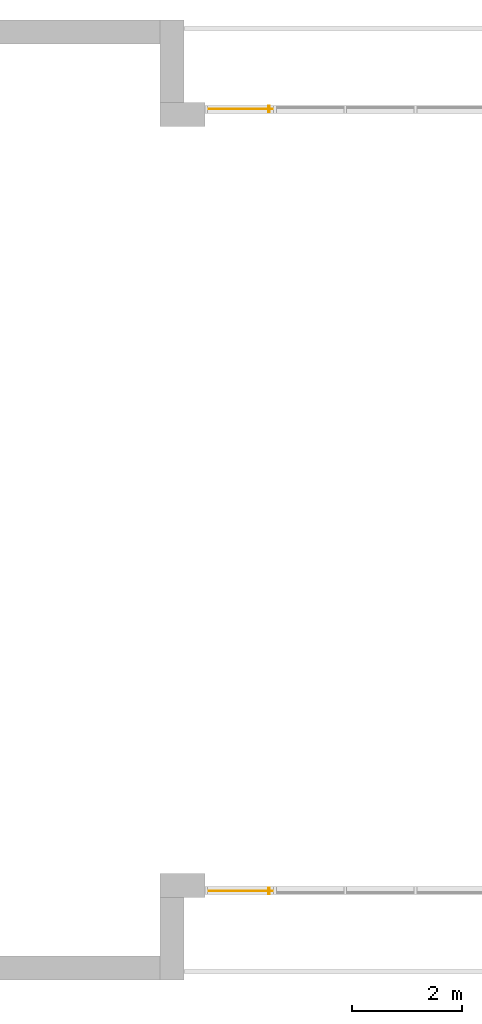
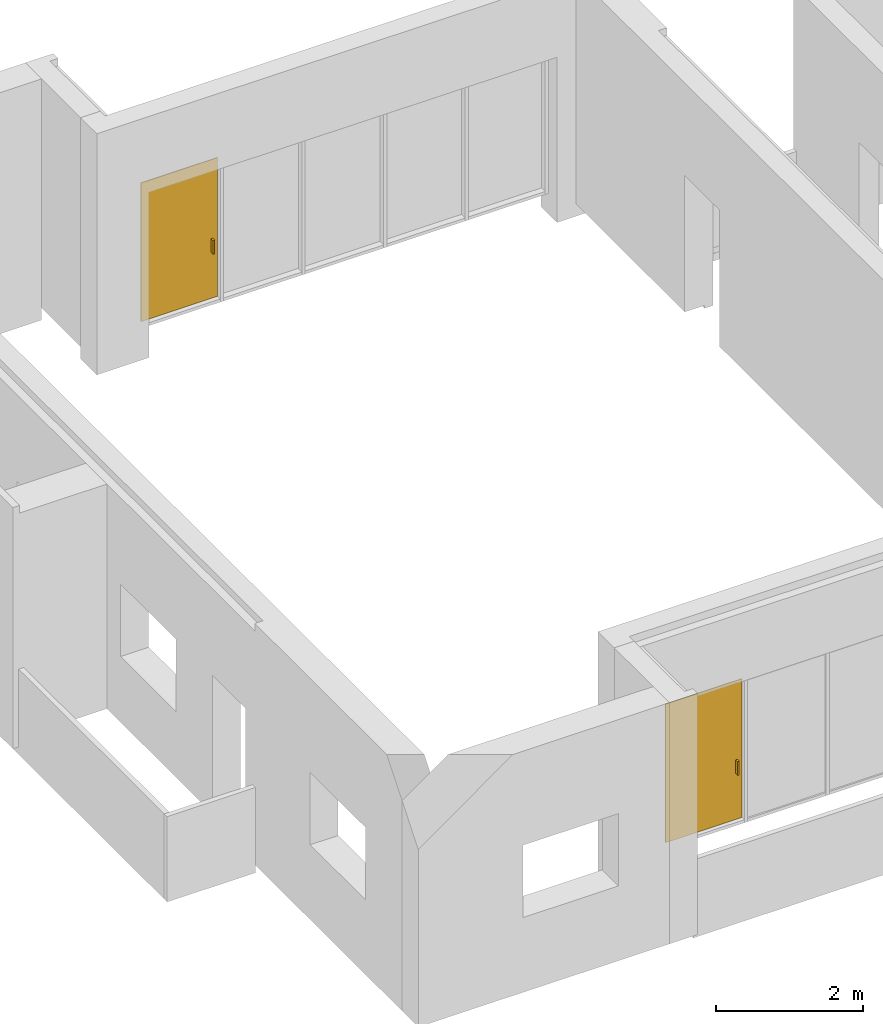
# One storey, part 4 of 4: 2 doors, 2 elements without a shape of their own.
"""IFC2X3 building model written with IfcOpenShell, lengths in millimetres."""

import ifcopenshell
import ifcopenshell.guid

model = None  # the IFC model being written
_history = None  # IfcOwnerHistory: only IFC2X3 demands one
_inside = {}  # id of a spatial element -> (the spatial element, [elements in it])
_under = {}  # id of a project, library or spatial element -> (it, [spatial elements below it])
_declared = {}  # id of a project -> (the project, [libraries it declares])
_typed = {}  # id of a type object -> (the type object, [elements of that type])
_made_of = {}  # id of a material, layer set ... -> (it, [elements and type objects made of it])


def new_model(schema):
    """Start an empty IFC model of exactly this schema.

    Asked for "IFC4X3", IfcOpenShell would pick the latest addendum, in which some entities
    have other attributes; the version numbers below select the first issue.
    IFC2X3 requires an IfcOwnerHistory on every rooted entity: one is made here for all.
    """
    global model, _history
    if schema == "IFC4X3":
        model = ifcopenshell.file(schema_version=(4, 3, 0, 0))
    else:
        model = ifcopenshell.file(schema=schema)
    _inside.clear()
    _under.clear()
    _declared.clear()
    _typed.clear()
    _made_of.clear()
    _history = None
    if model.schema == "IFC2X3":
        org = make("IfcOrganization", Name="unknown")
        user = make(
            "IfcPersonAndOrganization",
            ThePerson=make("IfcPerson", FamilyName="unknown"),
            TheOrganization=org,
        )
        app = make(
            "IfcApplication",
            ApplicationDeveloper=org,
            Version="unknown",
            ApplicationFullName="unknown",
            ApplicationIdentifier="unknown",
        )
        _history = make(
            "IfcOwnerHistory",
            OwningUser=user,
            OwningApplication=app,
            ChangeAction="ADDED",
            CreationDate=0,
        )
    return model


def make(cls, **values):
    """One entity of the class cls with the attributes given. An attribute that is None is left unset."""
    return model.create_entity(
        cls, **{name: value for name, value in values.items() if value is not None}
    )


def entity(cls, *values):
    """Any entity or typed value of the class cls, its attributes in the order of the schema. None: left unset."""
    e = model.create_entity(cls)
    for i, value in enumerate(values):
        if value is not None:
            e[i] = value
    return e


def rooted(cls, **values):
    """An entity with a GlobalId (a new one), such as an element, a storey or a relation."""
    return make(cls, GlobalId=ifcopenshell.guid.new(), OwnerHistory=_history, **values)


def si_unit(unit_type, name, prefix=None):
    """IfcSIUnit, for example si_unit("LENGTHUNIT", "METRE", prefix="MILLI")."""
    return make("IfcSIUnit", UnitType=unit_type, Prefix=prefix, Name=name)


def converted_unit(unit_type, name, factor, base, dimensions=None, offset=None):
    """IfcConversionBasedUnit, such as the inch: factor (a typed value) times the base unit."""
    return make(
        "IfcConversionBasedUnit"
        if offset is None
        else "IfcConversionBasedUnitWithOffset",
        ConversionOffset=offset,
        Dimensions=None
        if dimensions is None
        else entity("IfcDimensionalExponents", *dimensions),
        UnitType=unit_type,
        Name=name,
        ConversionFactor=make(
            "IfcMeasureWithUnit", ValueComponent=factor, UnitComponent=base
        ),
    )


def derived_unit(unit_type, elements):
    """IfcDerivedUnit: a product of units, each with its exponent."""
    return make(
        "IfcDerivedUnit",
        Elements=[
            make("IfcDerivedUnitElement", Unit=unit, Exponent=power)
            for unit, power in elements
        ],
        UnitType=unit_type,
    )


def assignment(units):
    """IfcUnitAssignment: the units of a project."""
    return None if units is None else make("IfcUnitAssignment", Units=units)


def point(xyz):
    """IfcCartesianPoint."""
    return None if xyz is None else make("IfcCartesianPoint", Coordinates=xyz)


def direction(xyz):
    """IfcDirection."""
    return None if xyz is None else make("IfcDirection", DirectionRatios=xyz)


def frame(location, z_axis=None, x_axis=None):
    """IfcAxis2Placement3D, a coordinate frame: its origin and axes. An axis left out is left unset."""
    return make(
        "IfcAxis2Placement3D",
        Location=point(location),
        Axis=direction(z_axis),
        RefDirection=direction(x_axis),
    )


def frame_2d(location, x_axis=None):
    """IfcAxis2Placement2D, a coordinate frame in the plane: its origin and x axis."""
    return make(
        "IfcAxis2Placement2D", Location=point(location), RefDirection=direction(x_axis)
    )


def origin():
    """The frame at (0, 0, 0) with its axes left unset."""
    return frame((0.0, 0.0, 0.0))


def origin_2d_with_axis():
    """The frame at (0, 0) in the plane with the x axis (1, 0) written out."""
    return frame_2d((0.0, 0.0), x_axis=(1.0, 0.0))


def place(relative_to, where):
    """IfcLocalPlacement: puts the frame where relative to a parent placement (None: the world)."""
    return make(
        "IfcLocalPlacement", PlacementRelTo=relative_to, RelativePlacement=where
    )


def context(
    kind, dimensions, precision=None, world=None, true_north=None, identifier=None
):
    """IfcGeometricRepresentationContext, for example the 3D "Model" context."""
    return make(
        "IfcGeometricRepresentationContext",
        ContextIdentifier=identifier,
        ContextType=kind,
        CoordinateSpaceDimension=dimensions,
        Precision=precision,
        WorldCoordinateSystem=world,
        TrueNorth=true_north,
    )


def subcontext(parent, identifier, kind, view, scale=None):
    """IfcGeometricRepresentationSubContext, for example "Body" below "Model"."""
    return make(
        "IfcGeometricRepresentationSubContext",
        ContextIdentifier=identifier,
        ContextType=kind,
        ParentContext=parent,
        TargetScale=scale,
        TargetView=view,
    )


def project(units=None, contexts=None):
    """IfcProject with its units and contexts."""
    return rooted(
        "IfcProject",
        Name="project",
        RepresentationContexts=contexts,
        UnitsInContext=assignment(units),
    )


def spatial(cls, under=None, at=None, **own):
    """A site, building, storey or space (cls), placed at a placement, below another one or the project."""
    s = rooted(cls, ObjectPlacement=at, **own)
    if under is not None:
        _under.setdefault(under.id(), (under, []))[1].append(s)
    return s


def profile(cls, at=None, kind="AREA", **sizes):
    """A parametric profile (cls). Its sizes go by their IFC names, for example OverallWidth=200.0."""
    return make(cls, ProfileType=kind, Position=at, **sizes)


def rectangle(**sizes):
    """IfcRectangleProfileDef."""
    return profile("IfcRectangleProfileDef", **sizes)


def extrude(swept, where, along, depth):
    """IfcExtrudedAreaSolid: the profile swept, set in the frame where, extruded along a direction by depth."""
    return make(
        "IfcExtrudedAreaSolid",
        SweptArea=swept,
        Position=where,
        ExtrudedDirection=direction(along),
        Depth=depth,
    )


def shape(context_of_items, identifier, shape_type, items):
    """IfcShapeRepresentation: the items that make up one representation, for example the "Body"."""
    return make(
        "IfcShapeRepresentation",
        ContextOfItems=context_of_items,
        RepresentationIdentifier=identifier,
        RepresentationType=shape_type,
        Items=items,
    )


def source(mapping_origin, context_of_items, identifier, shape_type, items):
    """IfcRepresentationMap: a shape defined once, which mapped items show again and again."""
    return make(
        "IfcRepresentationMap",
        MappingOrigin=mapping_origin,
        MappedRepresentation=shape(context_of_items, identifier, shape_type, items),
    )


def transform(
    local_origin,
    x_axis=None,
    y_axis=None,
    z_axis=None,
    scale=None,
    scale2=None,
    scale3=None,
    uniform=True,
):
    """IfcCartesianTransformationOperator3D, or its non-uniform kind. x_axis, y_axis, z_axis: its Axis1, 2, 3."""
    if uniform:
        return make(
            "IfcCartesianTransformationOperator3D",
            Axis1=direction(x_axis),
            Axis2=direction(y_axis),
            LocalOrigin=point(local_origin),
            Scale=scale,
            Axis3=direction(z_axis),
        )
    return make(
        "IfcCartesianTransformationOperator3DnonUniform",
        Axis1=direction(x_axis),
        Axis2=direction(y_axis),
        LocalOrigin=point(local_origin),
        Scale=scale,
        Axis3=direction(z_axis),
        Scale2=scale2,
        Scale3=scale3,
    )


def mapped(mapping_source, mapping_target):
    """IfcMappedItem: shows the shape of a source again, moved by a transform."""
    return make(
        "IfcMappedItem", MappingSource=mapping_source, MappingTarget=mapping_target
    )


def material(Name=None, Category=None):
    """IfcMaterial."""
    return make("IfcMaterial", Name=Name, Category=Category)


def material_list(materials):
    """IfcMaterialList."""
    return make("IfcMaterialList", Materials=materials)


def made_of(thing, what):
    """Note that an element or type object is made of a material, layer set ...; save() writes the relation."""
    if what is not None:
        _made_of.setdefault(what.id(), (what, []))[1].append(thing)
    return thing


def type_object(cls, material=None, **own):
    """A type object (cls), such as IfcWallType, which elements share."""
    return made_of(rooted(cls, **own), material)


def type_shapes(of_type, sources):
    """Give a type object the sources (RepresentationMaps) that its elements show as mapped items."""
    of_type.RepresentationMaps = sources


def element(
    cls,
    number,
    at=None,
    inside=None,
    cuts=None,
    type_object=None,
    material=None,
    context=None,
    identifier="Body",
    shape_type=None,
    held_by="IfcProductDefinitionShape",
    body=None,
    shapes=None,
    **own,
):
    """One element of the class cls, such as IfcWall. Its Tag is "e" and its number.

    at: its placement. inside: the storey or other place that contains it. cuts: it is an
    opening in that element (IfcRelVoidsElement). A single representation is given by context,
    identifier, shape_type and body (its items); several are given by shapes. held_by: the class
    of the entity that holds the representations. save() writes the other relations.
    """
    e = rooted(cls, Tag="e%d" % number, ObjectPlacement=at, **own)
    if body is not None:
        shapes = [shape(context, identifier, shape_type, body)]
    if shapes is not None:
        e.Representation = make(held_by, Representations=shapes)
    if inside is not None:
        _inside.setdefault(inside.id(), (inside, []))[1].append(e)
    if cuts is not None:
        rooted(
            "IfcRelVoidsElement", RelatingBuildingElement=cuts, RelatedOpeningElement=e
        )
    if type_object is not None:
        _typed.setdefault(type_object.id(), (type_object, []))[1].append(e)
    return made_of(e, material)


def aggregate(whole, parts):
    """IfcRelAggregates: a whole, such as a stair, and the parts it consists of."""
    return rooted("IfcRelAggregates", RelatingObject=whole, RelatedObjects=parts)


def save(model, path):
    """Write the relations noted so far, then the file.

    IfcRelAggregates (storeys below a building ...), IfcRelContainedInSpatialStructure (elements
    in a storey), IfcRelDefinesByType, IfcRelAssociatesMaterial and IfcRelDeclares: one each for
    every whole, place, type object, material and project.
    """
    for whole, parts in _under.values():
        aggregate(whole, parts)
    for where, things in _inside.values():
        rooted(
            "IfcRelContainedInSpatialStructure",
            RelatedElements=things,
            RelatingStructure=where,
        )
    for kind, things in _typed.values():
        rooted("IfcRelDefinesByType", RelatedObjects=things, RelatingType=kind)
    for what, things in _made_of.values():
        rooted("IfcRelAssociatesMaterial", RelatedObjects=things, RelatingMaterial=what)
    for by, libraries in _declared.values():
        rooted("IfcRelDeclares", RelatingContext=by, RelatedDefinitions=libraries)
    model.write(path)


model = new_model("IFC2X3")

# Units and contexts
model_context = context("Model", 3, precision=0.01, world=origin(), true_north=direction((6.12303176911189e-17, 1.0)))
body_context = subcontext(model_context, "Body", "Model", "MODEL_VIEW")
ifc_project = project(units=[si_unit("LENGTHUNIT", "METRE", prefix="MILLI"), si_unit("AREAUNIT", "SQUARE_METRE"), si_unit("VOLUMEUNIT", "CUBIC_METRE"), converted_unit("PLANEANGLEUNIT", "DEGREE", entity("IfcRatioMeasure", 0.0174532925199433), si_unit("PLANEANGLEUNIT", "RADIAN"), dimensions=[0, 0, 0, 0, 0, 0, 0]), si_unit("MASSUNIT", "GRAM", prefix="KILO"), derived_unit("MASSDENSITYUNIT", [(si_unit("MASSUNIT", "GRAM", prefix="KILO"), 1), (si_unit("LENGTHUNIT", "METRE"), -3)]), si_unit("TIMEUNIT", "SECOND"), si_unit("FREQUENCYUNIT", "HERTZ"), si_unit("THERMODYNAMICTEMPERATUREUNIT", "DEGREE_CELSIUS"), derived_unit("THERMALTRANSMITTANCEUNIT", [(si_unit("MASSUNIT", "GRAM", prefix="KILO"), 1), (si_unit("THERMODYNAMICTEMPERATUREUNIT", "KELVIN"), -1), (si_unit("TIMEUNIT", "SECOND"), -3)]), derived_unit("VOLUMETRICFLOWRATEUNIT", [(si_unit("LENGTHUNIT", "METRE"), 3), (si_unit("TIMEUNIT", "SECOND"), -1)]), si_unit("ELECTRICCURRENTUNIT", "AMPERE"), si_unit("ELECTRICVOLTAGEUNIT", "VOLT"), si_unit("POWERUNIT", "WATT"), si_unit("FORCEUNIT", "NEWTON", prefix="KILO"), si_unit("ILLUMINANCEUNIT", "LUX"), si_unit("LUMINOUSFLUXUNIT", "LUMEN"), si_unit("LUMINOUSINTENSITYUNIT", "CANDELA"), derived_unit("USERDEFINED", [(si_unit("MASSUNIT", "GRAM", prefix="KILO"), -1), (si_unit("LENGTHUNIT", "METRE"), -2), (si_unit("TIMEUNIT", "SECOND"), 3), (si_unit("LUMINOUSFLUXUNIT", "LUMEN"), 1)]), derived_unit("LINEARVELOCITYUNIT", [(si_unit("LENGTHUNIT", "METRE"), 1), (si_unit("TIMEUNIT", "SECOND"), -1)]), si_unit("PRESSUREUNIT", "PASCAL"), derived_unit("USERDEFINED", [(si_unit("LENGTHUNIT", "METRE"), -2), (si_unit("MASSUNIT", "GRAM", prefix="KILO"), 1), (si_unit("TIMEUNIT", "SECOND"), -2)])], contexts=[model_context])

# Site, building, storey
site_placement = place(None, origin())
site = spatial("IfcSite", under=ifc_project, at=site_placement, CompositionType="ELEMENT")
building_placement = place(site_placement, origin())
building = spatial("IfcBuilding", under=site, at=building_placement, CompositionType="ELEMENT")
storey_placement = place(building_placement, frame((0.0, 0.0, 4000.0)))
storey = spatial("IfcBuildingStorey", under=building, at=storey_placement, Name="01 Level", CompositionType="ELEMENT", Elevation=4000.0)

# Curtain wall, door
curtain_wall_type = type_object("IfcCurtainWallType", Name="Curtain Wall", PredefinedType="NOTDEFINED")
curtain_wall_1_placement = place(storey_placement, frame((0.0, 0.0, -4000.0)))
curtain_wall_1 = element("IfcCurtainWall", 1, at=curtain_wall_1_placement, inside=storey, type_object=curtain_wall_type, Name="Curtain Wall", ObjectType="Curtain Wall")
ifc_material_1 = material(Name="Glass")
ifc_material_2 = material(Name="Aluminum")
ifc_material_list_1 = material_list([ifc_material_1, ifc_material_2])
ifc_material_list_2 = material_list([ifc_material_1, ifc_material_2])
door_style_1 = type_object("IfcDoorStyle", Name="M_Door-Curtain-Wall-Single-Glass", ConstructionType="NOTDEFINED", OperationType="NOTDEFINED", ParameterTakesPrecedence=False, Sizeable=False, material=ifc_material_list_2)
shared_shape_1 = source(origin(), body_context, "Body", "SweptSolid", [
    extrude(rectangle(XDim=12.7000000000006, YDim=1204.99999999999, at=origin_2d_with_axis()), frame((0.0, 6.34999999998235, 0.0), z_axis=(0.0, 0.0, 1.0), x_axis=(0.0, 1.0, 0.0)), (0.0, 0.0, 1.0), 2300.0),
    extrude(rectangle(XDim=25.4, YDim=50.8, at=frame_2d((3.37507799486048e-14, 1.77635683940025e-15), x_axis=(1.0, 0.0))), frame((-513.599999999997, 38.0999999999827, 762.0), z_axis=(0.0, 0.0, 1.0), x_axis=(-1.0, 0.0, 0.0)), (0.0, 0.0, 1.0), 228.6),
    extrude(rectangle(XDim=25.3999999999997, YDim=50.8, at=frame_2d((-3.37507799486048e-14, 3.5527136788005e-15), x_axis=(1.0, 0.0))), frame((-513.599999999997, -25.400000000018, 762.0)), (0.0, 0.0, 1.0), 228.6),
])
type_shapes(door_style_1, [shared_shape_1])
door_1_placement = place(curtain_wall_1_placement, frame((22455.9900708518, -75951.2395851399, 4050.0), z_axis=(0.0, 0.0, 1.0), x_axis=(-1.0, 0.0, 0.0)))
door_1 = element("IfcDoor", 2, at=door_1_placement, type_object=door_style_1, material=ifc_material_list_1, OverallHeight=2300.0, OverallWidth=1205.0, context=body_context, shape_type="MappedRepresentation", body=[
    mapped(shared_shape_1, transform((0.0, 0.0, 0.0), scale=1.0)),
])
aggregate(curtain_wall_1, [door_1])

curtain_wall_2_placement = place(storey_placement, frame((0.0, 0.0, -4000.0)))
curtain_wall_2 = element("IfcCurtainWall", 3, at=curtain_wall_2_placement, inside=storey, type_object=curtain_wall_type, Name="Curtain Wall", ObjectType="Curtain Wall")
ifc_material_list_3 = material_list([ifc_material_1, ifc_material_2])
ifc_material_list_4 = material_list([ifc_material_1, ifc_material_2])
door_style_2 = type_object("IfcDoorStyle", Name="M_Door-Curtain-Wall-Single-Glass", ConstructionType="NOTDEFINED", OperationType="NOTDEFINED", ParameterTakesPrecedence=False, Sizeable=False, material=ifc_material_list_4)
shared_shape_2 = source(origin(), body_context, "Body", "SweptSolid", [
    extrude(rectangle(XDim=1204.99999999999, YDim=12.7000000000006, at=origin_2d_with_axis()), frame((0.0, -6.34999999998235, 0.0), z_axis=(0.0, 0.0, 1.0), x_axis=(-1.0, 0.0, 0.0)), (0.0, 0.0, 1.0), 2300.0),
    extrude(rectangle(XDim=50.8, YDim=25.4, at=frame_2d((-3.5527136788005e-15, -3.37507799486048e-14), x_axis=(1.0, 0.0))), frame((-513.599999999997, -38.0999999999827, 762.0), z_axis=(0.0, 0.0, 1.0), x_axis=(0.0, 1.0, 0.0)), (0.0, 0.0, 1.0), 228.6),
    extrude(rectangle(XDim=50.8, YDim=25.3999999999997, at=frame_2d((0.0, 3.37507799486048e-14), x_axis=(1.0, 0.0))), frame((-513.599999999997, 25.400000000018, 762.0), z_axis=(0.0, 0.0, 1.0), x_axis=(0.0, -1.0, 0.0)), (0.0, 0.0, 1.0), 228.6),
])
type_shapes(door_style_2, [shared_shape_2])
door_2_placement = place(curtain_wall_2_placement, frame((22455.9900708518, -61711.23958514, 4050.0), z_axis=(0.0, 0.0, 1.0), x_axis=(-1.0, 0.0, 0.0)))
door_2 = element("IfcDoor", 4, at=door_2_placement, type_object=door_style_2, material=ifc_material_list_3, OverallHeight=2300.0, OverallWidth=1205.0, context=body_context, shape_type="MappedRepresentation", body=[
    mapped(shared_shape_2, transform((0.0, 0.0, 0.0), scale=1.0)),
])
aggregate(curtain_wall_2, [door_2])

save(model, "model.ifc")
